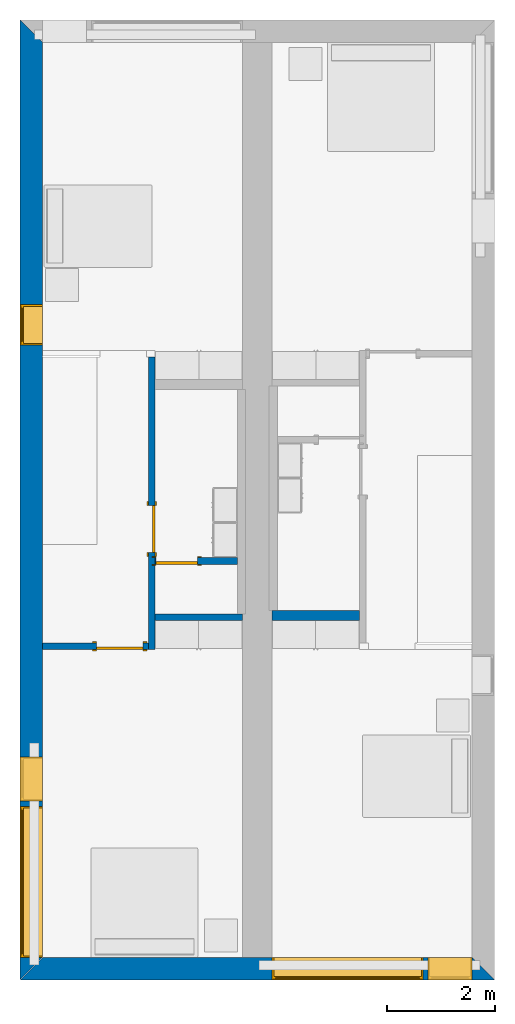
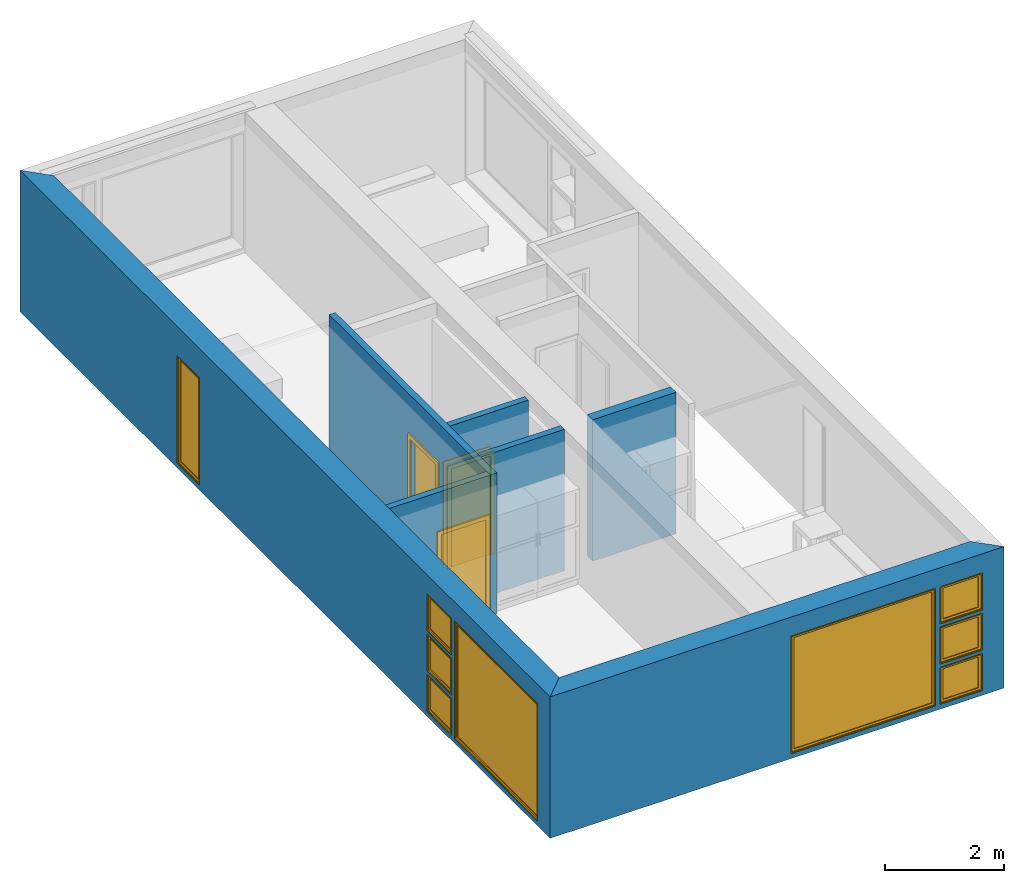
# One storey, part 2 of 16: 9 windows, 7 walls, 3 doors, 12 openings.
"""IFC2X3 building model written with IfcOpenShell, lengths in metres."""

import ifcopenshell
import ifcopenshell.guid

model = None  # the IFC model being written
_history = None  # IfcOwnerHistory: only IFC2X3 demands one
_inside = {}  # id of a spatial element -> (the spatial element, [elements in it])
_under = {}  # id of a project, library or spatial element -> (it, [spatial elements below it])
_declared = {}  # id of a project -> (the project, [libraries it declares])
_typed = {}  # id of a type object -> (the type object, [elements of that type])
_made_of = {}  # id of a material, layer set ... -> (it, [elements and type objects made of it])


def new_model(schema):
    """Start an empty IFC model of exactly this schema.

    Asked for "IFC4X3", IfcOpenShell would pick the latest addendum, in which some entities
    have other attributes; the version numbers below select the first issue.
    IFC2X3 requires an IfcOwnerHistory on every rooted entity: one is made here for all.
    """
    global model, _history
    if schema == "IFC4X3":
        model = ifcopenshell.file(schema_version=(4, 3, 0, 0))
    else:
        model = ifcopenshell.file(schema=schema)
    _inside.clear()
    _under.clear()
    _declared.clear()
    _typed.clear()
    _made_of.clear()
    _history = None
    if model.schema == "IFC2X3":
        org = make("IfcOrganization", Name="unknown")
        user = make(
            "IfcPersonAndOrganization",
            ThePerson=make("IfcPerson", FamilyName="unknown"),
            TheOrganization=org,
        )
        app = make(
            "IfcApplication",
            ApplicationDeveloper=org,
            Version="unknown",
            ApplicationFullName="unknown",
            ApplicationIdentifier="unknown",
        )
        _history = make(
            "IfcOwnerHistory",
            OwningUser=user,
            OwningApplication=app,
            ChangeAction="ADDED",
            CreationDate=0,
        )
    return model


def make(cls, **values):
    """One entity of the class cls with the attributes given. An attribute that is None is left unset."""
    return model.create_entity(
        cls, **{name: value for name, value in values.items() if value is not None}
    )


def entity(cls, *values):
    """Any entity or typed value of the class cls, its attributes in the order of the schema. None: left unset."""
    e = model.create_entity(cls)
    for i, value in enumerate(values):
        if value is not None:
            e[i] = value
    return e


def rooted(cls, **values):
    """An entity with a GlobalId (a new one), such as an element, a storey or a relation."""
    return make(cls, GlobalId=ifcopenshell.guid.new(), OwnerHistory=_history, **values)


def si_unit(unit_type, name, prefix=None):
    """IfcSIUnit, for example si_unit("LENGTHUNIT", "METRE", prefix="MILLI")."""
    return make("IfcSIUnit", UnitType=unit_type, Prefix=prefix, Name=name)


def converted_unit(unit_type, name, factor, base, dimensions=None, offset=None):
    """IfcConversionBasedUnit, such as the inch: factor (a typed value) times the base unit."""
    return make(
        "IfcConversionBasedUnit"
        if offset is None
        else "IfcConversionBasedUnitWithOffset",
        ConversionOffset=offset,
        Dimensions=None
        if dimensions is None
        else entity("IfcDimensionalExponents", *dimensions),
        UnitType=unit_type,
        Name=name,
        ConversionFactor=make(
            "IfcMeasureWithUnit", ValueComponent=factor, UnitComponent=base
        ),
    )


def assignment(units):
    """IfcUnitAssignment: the units of a project."""
    return None if units is None else make("IfcUnitAssignment", Units=units)


def point(xyz):
    """IfcCartesianPoint."""
    return None if xyz is None else make("IfcCartesianPoint", Coordinates=xyz)


def direction(xyz):
    """IfcDirection."""
    return None if xyz is None else make("IfcDirection", DirectionRatios=xyz)


def frame(location, z_axis=None, x_axis=None):
    """IfcAxis2Placement3D, a coordinate frame: its origin and axes. An axis left out is left unset."""
    return make(
        "IfcAxis2Placement3D",
        Location=point(location),
        Axis=direction(z_axis),
        RefDirection=direction(x_axis),
    )


def frame_2d(location, x_axis=None):
    """IfcAxis2Placement2D, a coordinate frame in the plane: its origin and x axis."""
    return make(
        "IfcAxis2Placement2D", Location=point(location), RefDirection=direction(x_axis)
    )


def origin():
    """The frame at (0, 0, 0) with its axes left unset."""
    return frame((0.0, 0.0, 0.0))


def origin_2d_with_axis():
    """The frame at (0, 0) in the plane with the x axis (1, 0) written out."""
    return frame_2d((0.0, 0.0), x_axis=(1.0, 0.0))


def place(relative_to, where):
    """IfcLocalPlacement: puts the frame where relative to a parent placement (None: the world)."""
    return make(
        "IfcLocalPlacement", PlacementRelTo=relative_to, RelativePlacement=where
    )


def context(
    kind, dimensions, precision=None, world=None, true_north=None, identifier=None
):
    """IfcGeometricRepresentationContext, for example the 3D "Model" context."""
    return make(
        "IfcGeometricRepresentationContext",
        ContextIdentifier=identifier,
        ContextType=kind,
        CoordinateSpaceDimension=dimensions,
        Precision=precision,
        WorldCoordinateSystem=world,
        TrueNorth=true_north,
    )


def project(units=None, contexts=None):
    """IfcProject with its units and contexts."""
    return rooted(
        "IfcProject",
        Name="project",
        RepresentationContexts=contexts,
        UnitsInContext=assignment(units),
    )


def spatial(cls, under=None, at=None, **own):
    """A site, building, storey or space (cls), placed at a placement, below another one or the project."""
    s = rooted(cls, ObjectPlacement=at, **own)
    if under is not None:
        _under.setdefault(under.id(), (under, []))[1].append(s)
    return s


def polyline(points):
    """IfcPolyline through the points."""
    return make("IfcPolyline", Points=[point(p) for p in points])


def profile(cls, at=None, kind="AREA", **sizes):
    """A parametric profile (cls). Its sizes go by their IFC names, for example OverallWidth=200.0."""
    return make(cls, ProfileType=kind, Position=at, **sizes)


def rectangle(**sizes):
    """IfcRectangleProfileDef."""
    return profile("IfcRectangleProfileDef", **sizes)


def outline(outer, holes=None, kind="AREA"):
    """IfcArbitraryClosedProfileDef: a profile drawn as a closed curve; with holes, ...WithVoids."""
    if holes is None:
        return make("IfcArbitraryClosedProfileDef", ProfileType=kind, OuterCurve=outer)
    return make(
        "IfcArbitraryProfileDefWithVoids",
        ProfileType=kind,
        OuterCurve=outer,
        InnerCurves=holes,
    )


def extrude(swept, where, along, depth):
    """IfcExtrudedAreaSolid: the profile swept, set in the frame where, extruded along a direction by depth."""
    return make(
        "IfcExtrudedAreaSolid",
        SweptArea=swept,
        Position=where,
        ExtrudedDirection=direction(along),
        Depth=depth,
    )


def shape(context_of_items, identifier, shape_type, items):
    """IfcShapeRepresentation: the items that make up one representation, for example the "Body"."""
    return make(
        "IfcShapeRepresentation",
        ContextOfItems=context_of_items,
        RepresentationIdentifier=identifier,
        RepresentationType=shape_type,
        Items=items,
    )


def source(mapping_origin, context_of_items, identifier, shape_type, items):
    """IfcRepresentationMap: a shape defined once, which mapped items show again and again."""
    return make(
        "IfcRepresentationMap",
        MappingOrigin=mapping_origin,
        MappedRepresentation=shape(context_of_items, identifier, shape_type, items),
    )


def transform(
    local_origin,
    x_axis=None,
    y_axis=None,
    z_axis=None,
    scale=None,
    scale2=None,
    scale3=None,
    uniform=True,
):
    """IfcCartesianTransformationOperator3D, or its non-uniform kind. x_axis, y_axis, z_axis: its Axis1, 2, 3."""
    if uniform:
        return make(
            "IfcCartesianTransformationOperator3D",
            Axis1=direction(x_axis),
            Axis2=direction(y_axis),
            LocalOrigin=point(local_origin),
            Scale=scale,
            Axis3=direction(z_axis),
        )
    return make(
        "IfcCartesianTransformationOperator3DnonUniform",
        Axis1=direction(x_axis),
        Axis2=direction(y_axis),
        LocalOrigin=point(local_origin),
        Scale=scale,
        Axis3=direction(z_axis),
        Scale2=scale2,
        Scale3=scale3,
    )


def mapped(mapping_source, mapping_target):
    """IfcMappedItem: shows the shape of a source again, moved by a transform."""
    return make(
        "IfcMappedItem", MappingSource=mapping_source, MappingTarget=mapping_target
    )


def material(Name=None, Category=None):
    """IfcMaterial."""
    return make("IfcMaterial", Name=Name, Category=Category)


def layer(
    of_material, thickness, ventilated=None, Name=None, Category=None, Priority=None
):
    """IfcMaterialLayer: one layer of a wall or slab, of a material (None: an air gap)."""
    return make(
        "IfcMaterialLayer",
        Material=of_material,
        LayerThickness=thickness,
        IsVentilated=ventilated,
        Name=Name,
        Category=Category,
        Priority=Priority,
    )


def layer_set(layers, Name=None):
    """IfcMaterialLayerSet."""
    return make("IfcMaterialLayerSet", MaterialLayers=layers, LayerSetName=Name)


def layer_usage(for_layer_set, set_direction, sense, offset, extent=None):
    """IfcMaterialLayerSetUsage: how a layer set lies in its element."""
    return make(
        "IfcMaterialLayerSetUsage",
        ForLayerSet=for_layer_set,
        LayerSetDirection=set_direction,
        DirectionSense=sense,
        OffsetFromReferenceLine=offset,
        ReferenceExtent=extent,
    )


def made_of(thing, what):
    """Note that an element or type object is made of a material, layer set ...; save() writes the relation."""
    if what is not None:
        _made_of.setdefault(what.id(), (what, []))[1].append(thing)
    return thing


def type_object(cls, material=None, **own):
    """A type object (cls), such as IfcWallType, which elements share."""
    return made_of(rooted(cls, **own), material)


def type_shapes(of_type, sources):
    """Give a type object the sources (RepresentationMaps) that its elements show as mapped items."""
    of_type.RepresentationMaps = sources


def element(
    cls,
    number,
    at=None,
    inside=None,
    cuts=None,
    type_object=None,
    material=None,
    context=None,
    identifier="Body",
    shape_type=None,
    held_by="IfcProductDefinitionShape",
    body=None,
    shapes=None,
    **own,
):
    """One element of the class cls, such as IfcWall. Its Tag is "e" and its number.

    at: its placement. inside: the storey or other place that contains it. cuts: it is an
    opening in that element (IfcRelVoidsElement). A single representation is given by context,
    identifier, shape_type and body (its items); several are given by shapes. held_by: the class
    of the entity that holds the representations. save() writes the other relations.
    """
    e = rooted(cls, Tag="e%d" % number, ObjectPlacement=at, **own)
    if body is not None:
        shapes = [shape(context, identifier, shape_type, body)]
    if shapes is not None:
        e.Representation = make(held_by, Representations=shapes)
    if inside is not None:
        _inside.setdefault(inside.id(), (inside, []))[1].append(e)
    if cuts is not None:
        rooted(
            "IfcRelVoidsElement", RelatingBuildingElement=cuts, RelatedOpeningElement=e
        )
    if type_object is not None:
        _typed.setdefault(type_object.id(), (type_object, []))[1].append(e)
    return made_of(e, material)


def fill(opening, filler):
    """IfcRelFillsElement: the door or window that sits in an opening."""
    return rooted(
        "IfcRelFillsElement",
        RelatingOpeningElement=opening,
        RelatedBuildingElement=filler,
    )


def aggregate(whole, parts):
    """IfcRelAggregates: a whole, such as a stair, and the parts it consists of."""
    return rooted("IfcRelAggregates", RelatingObject=whole, RelatedObjects=parts)


def save(model, path):
    """Write the relations noted so far, then the file.

    IfcRelAggregates (storeys below a building ...), IfcRelContainedInSpatialStructure (elements
    in a storey), IfcRelDefinesByType, IfcRelAssociatesMaterial and IfcRelDeclares: one each for
    every whole, place, type object, material and project.
    """
    for whole, parts in _under.values():
        aggregate(whole, parts)
    for where, things in _inside.values():
        rooted(
            "IfcRelContainedInSpatialStructure",
            RelatedElements=things,
            RelatingStructure=where,
        )
    for kind, things in _typed.values():
        rooted("IfcRelDefinesByType", RelatedObjects=things, RelatingType=kind)
    for what, things in _made_of.values():
        rooted("IfcRelAssociatesMaterial", RelatedObjects=things, RelatingMaterial=what)
    for by, libraries in _declared.values():
        rooted("IfcRelDeclares", RelatingContext=by, RelatedDefinitions=libraries)
    model.write(path)


model = new_model("IFC2X3")

# Units and contexts
model_context = context("Model", 3, precision=1e-09, world=origin())
plan_context = context("Plan", 3, precision=1e-09, world=origin())
ifc_project = project(units=[si_unit("LENGTHUNIT", "METRE"), si_unit("AREAUNIT", "SQUARE_METRE"), si_unit("VOLUMEUNIT", "CUBIC_METRE"), converted_unit("PLANEANGLEUNIT", "DEGREE", entity("IfcRatioMeasure", 0.01745329251994328), si_unit("PLANEANGLEUNIT", "RADIAN"), dimensions=[0, 0, 0, 0, 0, 0, 0]), si_unit("TIMEUNIT", "SECOND")], contexts=[model_context, plan_context])

# Site, building, storey
site_placement = place(None, origin())
site = spatial("IfcSite", under=ifc_project, at=site_placement, CompositionType="ELEMENT")
building_placement = place(site_placement, origin())
building = spatial("IfcBuilding", under=site, at=building_placement, CompositionType="ELEMENT")
storey_placement = place(building_placement, frame((0.0, 0.0, 3.100000000000196)))
storey = spatial("IfcBuildingStorey", under=building, at=storey_placement, Name="Level 2", CompositionType="ELEMENT", Elevation=3.100000000000196)

# Wall, openings, windows
ifc_material_1 = material(Name="Masonry - Brick")
ifc_layer_1 = layer(ifc_material_1, 0.092)
ifc_material_2 = material(Name="Misc. Air Layers - Air Space")
ifc_layer_2 = layer(ifc_material_2, 0.025)
ifc_material_3 = material(Name="Insulation / Thermal Barriers - Rigid insulation")
ifc_layer_3 = layer(ifc_material_3, 0.05)
ifc_material_4 = material(Name="Masonry - Concrete Block")
ifc_layer_4 = layer(ifc_material_4, 0.193)
ifc_material_5 = material(Name="Metal - Stud Layer")
ifc_layer_5 = layer(ifc_material_5, 0.041)
ifc_material_6 = material(Name="Plasterboard")
ifc_layer_6 = layer(ifc_material_6, 0.016)
ifc_layer_set_1 = layer_set([ifc_layer_1, ifc_layer_2, ifc_layer_3, ifc_layer_4, ifc_layer_5, ifc_layer_6], Name="Basic Wall:Exterior - Brick on Block")
ifc_layer_usage_1 = layer_usage(ifc_layer_set_1, "AXIS2", "NEGATIVE", 0.2085000000000001)
wall_1_placement = place(storey_placement, frame((8.799999999999974, -17.5915, 0.0), z_axis=(0.0, 0.0, 1.0), x_axis=(-1.0, 0.0, 0.0)))
wall_1 = element("IfcWallStandardCase", 1, at=wall_1_placement, inside=storey, material=ifc_layer_usage_1, Name="Basic Wall:Exterior - Brick on Block", ObjectType="Basic Wall:Exterior - Brick on Block", context=model_context, shape_type="SweptSolid", body=[
    extrude(outline(polyline([(8.382999999999974, -0.2084999999999994), (8.799999999999974, 0.2085000000000002), (0.0, 0.2085000000000002), (0.4170000000000034, -0.2085000000000011), (4.125000000000003, -0.2085000000000001), (4.675000000000003, -0.2085000000000005), (8.382999999999974, -0.2084999999999994)])), origin(), (0.0, 0.0, 1.0), 2.900000000000012),
])
opening_1_placement = place(wall_1_placement, frame((1.325000000000001, -0.2084999999999981, 0.1000000000000054)))
opening_1 = element("IfcOpeningElement", 2, at=opening_1_placement, cuts=wall_1, ObjectType="Opening", context=model_context, shape_type="SweptSolid", body=[
    extrude(rectangle(XDim=2.409999999999996, YDim=2.8, at=frame_2d((1.204999999999998, 1.4), x_axis=(1.0, 0.0))), frame((0.0, 0.0, 0.0), z_axis=(0.0, 1.0, 0.0), x_axis=(0.0, 0.0, 1.0)), (0.0, 0.0, 1.0), 0.4170000000000001),
])
opening_2_placement = place(wall_1_placement, frame((0.4170000000000005, -0.2084999999999993, 0.100000000000006)))
opening_2 = element("IfcOpeningElement", 3, at=opening_2_placement, cuts=wall_1, ObjectType="Opening", context=model_context, shape_type="SweptSolid", body=[
    extrude(rectangle(XDim=0.7589999999999981, YDim=0.8189999999999995, at=frame_2d((0.379499999999999, 0.4095000000000003), x_axis=(1.0, 0.0))), frame((0.0, 0.0, 0.0), z_axis=(0.0, 1.0, 0.0), x_axis=(0.0, 0.0, 1.0)), (0.0, 0.0, 1.0), 0.4170000000000001),
])
opening_3_placement = place(wall_1_placement, frame((0.4170000000000168, -0.2084999999999998, 0.9255000000000008)))
opening_3 = element("IfcOpeningElement", 4, at=opening_3_placement, cuts=wall_1, ObjectType="Opening", context=model_context, shape_type="SweptSolid", body=[
    extrude(rectangle(XDim=0.7590000000000007, YDim=0.8189999999999998, at=frame_2d((0.3795000000000003, 0.4094999999999999), x_axis=(-1.0, 0.0))), frame((0.0, 0.0, 0.0), z_axis=(0.0, 1.0, 0.0), x_axis=(0.0, 0.0, 1.0)), (0.0, 0.0, 1.0), 0.4170000000000001),
])
opening_4_placement = place(wall_1_placement, frame((0.4170000000000005, -0.2084999999999993, 1.751000000000001)))
opening_4 = element("IfcOpeningElement", 5, at=opening_4_placement, cuts=wall_1, ObjectType="Opening", context=model_context, shape_type="SweptSolid", body=[
    extrude(rectangle(XDim=0.7589999999999981, YDim=0.8189999999999995, at=frame_2d((0.379499999999999, 0.4095000000000003), x_axis=(1.0, 0.0))), frame((0.0, 0.0, 0.0), z_axis=(0.0, 1.0, 0.0), x_axis=(0.0, 0.0, 1.0)), (0.0, 0.0, 1.0), 0.4170000000000001),
])
window_style_1 = type_object("IfcWindowStyle", Name="2800mm x 2410mm", ConstructionType="NOTDEFINED", OperationType="NOTDEFINED", ParameterTakesPrecedence=False, Sizeable=False)
shared_shape_1 = source(origin(), model_context, "Body", "SweptSolid", [
    extrude(rectangle(XDim=0.01199999999999998, YDim=2.673999999999997, at=origin_2d_with_axis()), frame((1.400000000000007, 0.3759999999999956, 0.06299999999998514), z_axis=(0.0, 0.0, 1.0), x_axis=(0.0, -1.0, 0.0)), (0.0, 0.0, 1.0), 2.284000000000005),
    extrude(outline(polyline([(-1.381, -1.186000000000001), (1.381, -1.186000000000001), (1.381, 1.186000000000001), (-1.381, 1.186000000000001), (-1.381, -1.186000000000001)]), holes=[polyline([(-1.336999999999999, -1.142000000000002), (-1.336999999999999, 1.142000000000003), (1.336999999999997, 1.142000000000003), (1.336999999999997, -1.142000000000002), (-1.336999999999999, -1.142000000000002)])]), frame((1.400000000000008, 0.3539999999999681, 1.204999999999988), z_axis=(0.0, 1.0, 0.0), x_axis=(1.0, 0.0, 0.0)), (0.0, 0.0, 1.0), 0.04400000000002743),
    extrude(outline(polyline([(-1.4, -1.204999999999996), (1.4, -1.204999999999996), (1.4, 1.204999999999996), (-1.4, 1.204999999999996), (-1.4, -1.204999999999996)]), holes=[polyline([(-1.381000000000001, -1.185999999999981), (-1.381000000000001, 1.186000000000022), (1.380999999999999, 1.186000000000022), (1.380999999999999, -1.185999999999981), (-1.381000000000001, -1.185999999999981)])]), frame((1.400000000000009, 0.3539999999999681, 1.205000000000009), z_axis=(0.0, 1.0, 0.0), x_axis=(1.0, 0.0, 0.0)), (0.0, 0.0, 1.0), 0.06300000000002744),
    extrude(outline(polyline([(-1.4, -1.204999999999995), (1.4, -1.204999999999995), (1.4, 1.204999999999995), (-1.4, 1.204999999999995), (-1.4, -1.204999999999995)]), holes=[polyline([(-1.368, -1.172999999999982), (-1.368, 1.17300000000002), (1.368, 1.17300000000002), (1.367999999999999, -1.172999999999982), (-1.368, -1.172999999999982)])]), frame((1.40000000000001, 0.0, 1.205000000000008), z_axis=(0.0, 1.0, 0.0), x_axis=(1.0, 0.0, 0.0)), (0.0, 0.0, 1.0), 0.3539999999999727),
])
type_shapes(window_style_1, [shared_shape_1])
window_1_placement = place(opening_1_placement, origin())
window_1 = element("IfcWindow", 6, at=window_1_placement, inside=storey, type_object=window_style_1, ObjectType="2800mm x 2410mm", OverallHeight=2.409999999999996, OverallWidth=2.8, context=model_context, shape_type="MappedRepresentation", body=[
    mapped(shared_shape_1, transform((0.0, 0.0, 0.0), scale=1.0)),
])
fill(opening_1, window_1)
window_style_2 = type_object("IfcWindowStyle", Name="819mm x 759mm", ConstructionType="NOTDEFINED", OperationType="NOTDEFINED", ParameterTakesPrecedence=False, Sizeable=False)
shared_shape_2 = source(origin(), model_context, "Body", "SweptSolid", [
    extrude(rectangle(XDim=0.01199999999999998, YDim=0.6929999999999971, at=origin_2d_with_axis()), frame((0.4095000000000068, 0.3759999999999988, 0.06299999999998514), z_axis=(0.0, 0.0, 1.0), x_axis=(0.0, -1.0, 0.0)), (0.0, 0.0, 1.0), 0.6330000000000073),
    extrude(outline(polyline([(-0.3904999999999999, -0.3605000000000028), (0.3904999999999999, -0.3605000000000028), (0.3904999999999999, 0.3605000000000027), (-0.3904999999999999, 0.3605000000000027), (-0.3904999999999999, -0.3605000000000028)]), holes=[polyline([(-0.3464999999999996, -0.3165000000000033), (-0.3464999999999996, 0.316500000000004), (0.3464999999999974, 0.316500000000004), (0.3464999999999974, -0.3165000000000033), (-0.3464999999999996, -0.3165000000000033)])]), frame((0.4095000000000078, 0.3539999999999714, 0.3794999999999891), z_axis=(0.0, 1.0, 0.0), x_axis=(1.0, 0.0, 0.0)), (0.0, 0.0, 1.0), 0.04400000000002743),
    extrude(outline(polyline([(-0.4094999999999998, -0.3794999999999972), (0.4094999999999998, -0.3794999999999972), (0.4094999999999998, 0.3794999999999971), (-0.4094999999999998, 0.3794999999999971), (-0.4094999999999998, -0.3794999999999972)]), holes=[polyline([(-0.3905000000000011, -0.3604999999999823), (-0.3905000000000012, 0.3605000000000231), (0.3904999999999986, 0.3605000000000231), (0.3904999999999987, -0.3604999999999823), (-0.3905000000000011, -0.3604999999999823)])]), frame((0.4095000000000091, 0.3539999999999714, 0.3795000000000096), z_axis=(0.0, 1.0, 0.0), x_axis=(1.0, 0.0, 0.0)), (0.0, 0.0, 1.0), 0.06300000000002744),
    extrude(outline(polyline([(-0.4095000000000002, -0.3794999999999967), (0.4095000000000002, -0.3794999999999967), (0.4095000000000002, 0.3794999999999966), (-0.4095000000000002, 0.3794999999999966), (-0.4095000000000002, -0.3794999999999967)]), holes=[polyline([(-0.3774999999999999, -0.3474999999999832), (-0.3774999999999999, 0.3475000000000212), (0.3775000000000001, 0.3475000000000212), (0.3775000000000001, -0.3474999999999832), (-0.3774999999999999, -0.3474999999999832)])]), frame((0.4095000000000096, 0.0, 0.379500000000009), z_axis=(0.0, 1.0, 0.0), x_axis=(1.0, 0.0, 0.0)), (0.0, 0.0, 1.0), 0.3539999999999727),
])
type_shapes(window_style_2, [shared_shape_2])
window_2_placement = place(opening_2_placement, origin())
window_2 = element("IfcWindow", 7, at=window_2_placement, inside=storey, type_object=window_style_2, ObjectType="819mm x 759mm", OverallHeight=0.758999999999998, OverallWidth=0.8190000000000001, context=model_context, shape_type="MappedRepresentation", body=[
    mapped(shared_shape_2, transform((0.0, 0.0, 0.0), scale=1.0)),
])
fill(opening_2, window_2)
window_3_placement = place(opening_4_placement, origin())
window_3 = element("IfcWindow", 8, at=window_3_placement, inside=storey, type_object=window_style_2, ObjectType="819mm x 759mm", OverallHeight=0.758999999999998, OverallWidth=0.8190000000000001, context=model_context, shape_type="MappedRepresentation", body=[
    mapped(shared_shape_2, transform((0.0, 0.0, 0.0), scale=1.0)),
])
fill(opening_4, window_3)
window_style_3 = type_object("IfcWindowStyle", Name="819mm x 759mm", ConstructionType="NOTDEFINED", OperationType="NOTDEFINED", ParameterTakesPrecedence=False, Sizeable=False)
shared_shape_3 = source(origin(), model_context, "Body", "SweptSolid", [
    extrude(rectangle(XDim=0.01269999999999999, YDim=0.6919999999999978, at=origin_2d_with_axis()), frame((0.4095000000000003, 0.3757750000000001, 0.06350000000000397), z_axis=(0.0, 0.0, 1.0), x_axis=(0.0, 1.0, 0.0)), (0.0, 0.0, 1.0), 0.6320000000000041),
    extrude(outline(polyline([(-0.3904499999999989, -0.3604500000000012), (0.3904499999999989, -0.3604500000000012), (0.3904499999999989, 0.3604500000000012), (-0.3904499999999989, 0.3604500000000012), (-0.3904499999999989, -0.3604500000000012)]), holes=[polyline([(-0.3459999999999978, -0.3160000000000016), (-0.3459999999999978, 0.3160000000000026), (0.346, 0.3160000000000026), (0.346, -0.3160000000000016), (-0.3459999999999978, -0.3160000000000016)])]), frame((0.4094999999999992, 0.3535500000000001, 0.3795000000000066), z_axis=(0.0, 1.0, 0.0), x_axis=(1.0, 0.0, 0.0)), (0.0, 0.0, 1.0), 0.04445),
    extrude(outline(polyline([(-0.4094999999999992, -0.3795000000000012), (0.4094999999999992, -0.3795000000000012), (0.4094999999999992, 0.3795000000000012), (-0.4094999999999992, 0.3795000000000012), (-0.4094999999999992, -0.3795000000000012)]), holes=[polyline([(-0.3777500000000001, -0.3477499999999997), (-0.3777500000000001, 0.3477500000000008), (0.3777499999999982, 0.3477500000000008), (0.3777499999999982, -0.3477499999999997), (-0.3777500000000001, -0.3477499999999997)])]), frame((0.4095000000000007, 0.0, 0.3795000000000077), z_axis=(0.0, 1.0, 0.0), x_axis=(1.0, 0.0, 0.0)), (0.0, 0.0, 1.0), 0.3535500000000001),
    extrude(outline(polyline([(-0.3795000000000017, -0.4094999999999995), (0.3795000000000017, -0.4094999999999995), (0.3795000000000017, 0.4094999999999995), (-0.3795000000000017, 0.4094999999999995), (-0.3795000000000017, -0.4094999999999995)]), holes=[polyline([(-0.3604500000000023, -0.3904499999999987), (-0.3604500000000023, 0.3904499999999997), (0.3604500000000017, 0.3904499999999997), (0.3604500000000017, -0.3904499999999988), (-0.3604500000000023, -0.3904499999999987)])]), frame((0.4095000000000004, 0.3535500000000001, 0.3795000000000071), z_axis=(0.0, 1.0, 0.0), x_axis=(0.0, 0.0, -1.0)), (0.0, 0.0, 1.0), 0.06345),
])
type_shapes(window_style_3, [shared_shape_3])
window_4_placement = place(opening_3_placement, origin())
window_4 = element("IfcWindow", 9, at=window_4_placement, inside=storey, type_object=window_style_3, ObjectType="819mm x 759mm", OverallHeight=0.7590000000000007, OverallWidth=0.8190000000000001, context=model_context, shape_type="MappedRepresentation", body=[
    mapped(shared_shape_3, transform((0.0, 0.0, 0.0), scale=1.0)),
])
fill(opening_3, window_4)

ifc_layer_usage_2 = layer_usage(ifc_layer_set_1, "AXIS2", "NEGATIVE", 0.2085000000000001)
wall_2_placement = place(storey_placement, frame((0.208499999999999, -17.79999999999997, 0.0), z_axis=(0.0, 0.0, 1.0), x_axis=(0.0, 1.0, 0.0)))
wall_2 = element("IfcWallStandardCase", 10, at=wall_2_placement, inside=storey, material=ifc_layer_usage_2, Name="Basic Wall:Exterior - Brick on Block", ObjectType="Basic Wall:Exterior - Brick on Block", context=model_context, shape_type="SweptSolid", body=[
    extrude(outline(polyline([(17.38299999999997, -0.2085000000000001), (17.79999999999997, 0.2085000000000001), (0.0, 0.2085000000000001), (0.4170000000000005, -0.2085), (6.125999999999976, -0.2085), (6.249999999999976, -0.2085000000000001), (17.38299999999997, -0.2085000000000001)])), origin(), (0.0, 0.0, 1.0), 2.900000000000013),
])
opening_5_placement = place(wall_2_placement, frame((0.4169999999999983, -0.2084999999999956, 0.1000000000000011)))
opening_5 = element("IfcOpeningElement", 11, at=opening_5_placement, cuts=wall_2, ObjectType="Opening", context=model_context, shape_type="SweptSolid", body=[
    extrude(rectangle(XDim=2.409999999999996, YDim=2.8, at=frame_2d((1.204999999999998, 1.4), x_axis=(1.0, 0.0))), frame((0.0, 0.0, 0.0), z_axis=(0.0, 1.0, 0.0), x_axis=(0.0, 0.0, 1.0)), (0.0, 0.0, 1.0), 0.4170000000000001),
])
opening_6_placement = place(wall_2_placement, frame((3.317, -0.208499999999999, 1.751000000000001)))
opening_6 = element("IfcOpeningElement", 12, at=opening_6_placement, cuts=wall_2, ObjectType="Opening", context=model_context, shape_type="SweptSolid", body=[
    extrude(rectangle(XDim=0.7589999999999981, YDim=0.8189999999999995, at=frame_2d((0.379499999999999, 0.4095000000000003), x_axis=(1.0, 0.0))), frame((0.0, 0.0, 0.0), z_axis=(0.0, 1.0, 0.0), x_axis=(0.0, 0.0, 1.0)), (0.0, 0.0, 1.0), 0.4170000000000001),
])
opening_7_placement = place(wall_2_placement, frame((3.317, -0.208499999999999, 0.1000000000000011)))
opening_7 = element("IfcOpeningElement", 13, at=opening_7_placement, cuts=wall_2, ObjectType="Opening", context=model_context, shape_type="SweptSolid", body=[
    extrude(rectangle(XDim=0.7589999999999981, YDim=0.8189999999999995, at=frame_2d((0.3794999999999993, 0.4095000000000003), x_axis=(1.0, 0.0))), frame((0.0, 0.0, 0.0), z_axis=(0.0, 1.0, 0.0), x_axis=(0.0, 0.0, 1.0)), (0.0, 0.0, 1.0), 0.4170000000000001),
])
opening_8_placement = place(wall_2_placement, frame((3.317000000000015, -0.2085000000000003, 0.9255000000000008)))
opening_8 = element("IfcOpeningElement", 14, at=opening_8_placement, cuts=wall_2, ObjectType="Opening", context=model_context, shape_type="SweptSolid", body=[
    extrude(rectangle(XDim=0.7590000000000007, YDim=0.8189999999999998, at=frame_2d((0.3795000000000003, 0.4094999999999999), x_axis=(-1.0, 0.0))), frame((0.0, 0.0, 0.0), z_axis=(0.0, 1.0, 0.0), x_axis=(0.0, 0.0, 1.0)), (0.0, 0.0, 1.0), 0.4170000000000001),
])
opening_9_placement = place(wall_2_placement, frame((11.77399999999997, -0.2084999999999996, 0.1000000000000011)))
opening_9 = element("IfcOpeningElement", 15, at=opening_9_placement, cuts=wall_2, ObjectType="Opening", context=model_context, shape_type="SweptSolid", body=[
    extrude(rectangle(XDim=2.199999999999996, YDim=0.7499999999999996, at=frame_2d((1.099999999999999, 0.3749999999999987), x_axis=(1.0, 0.0))), frame((0.0, 0.0, 0.0), z_axis=(0.0, 1.0, 0.0), x_axis=(0.0, 0.0, 1.0)), (0.0, 0.0, 1.0), 0.4170000000000001),
])
window_style_4 = type_object("IfcWindowStyle", Name="750mm x 2200mm", ConstructionType="NOTDEFINED", OperationType="NOTDEFINED", ParameterTakesPrecedence=False, Sizeable=False)
shared_shape_4 = source(origin(), model_context, "Body", "SweptSolid", [
    extrude(rectangle(XDim=0.01199999999999998, YDim=0.623999999999997, at=origin_2d_with_axis()), frame((0.375000000000007, 0.3759999999999988, 0.06299999999998514), z_axis=(0.0, 0.0, 1.0), x_axis=(0.0, -1.0, 0.0)), (0.0, 0.0, 1.0), 2.074000000000006),
    extrude(outline(polyline([(-0.3559999999999999, -1.081000000000002), (0.3559999999999999, -1.081000000000002), (0.3559999999999999, 1.081000000000002), (-0.3559999999999999, 1.081000000000002), (-0.3559999999999999, -1.081000000000002)]), holes=[polyline([(-0.3119999999999996, -1.037000000000002), (-0.3119999999999996, 1.037000000000003), (0.3119999999999975, 1.037000000000003), (0.3119999999999975, -1.037000000000002), (-0.3119999999999996, -1.037000000000002)])]), frame((0.3750000000000081, 0.3539999999999715, 1.099999999999989), z_axis=(0.0, 1.0, 0.0), x_axis=(1.0, 0.0, 0.0)), (0.0, 0.0, 1.0), 0.04400000000002743),
    extrude(outline(polyline([(-0.3749999999999997, -1.099999999999996), (0.3749999999999997, -1.099999999999996), (0.3749999999999997, 1.099999999999996), (-0.3749999999999997, 1.099999999999996), (-0.3749999999999997, -1.099999999999996)]), holes=[polyline([(-0.3560000000000012, -1.080999999999981), (-0.3560000000000013, 1.081000000000022), (0.3559999999999985, 1.081000000000022), (0.3559999999999986, -1.080999999999981), (-0.3560000000000012, -1.080999999999981)])]), frame((0.3750000000000094, 0.3539999999999715, 1.100000000000009), z_axis=(0.0, 1.0, 0.0), x_axis=(1.0, 0.0, 0.0)), (0.0, 0.0, 1.0), 0.06300000000002744),
    extrude(outline(polyline([(-0.3750000000000001, -1.099999999999996), (0.3750000000000001, -1.099999999999996), (0.3750000000000001, 1.099999999999996), (-0.3750000000000001, 1.099999999999996), (-0.3750000000000001, -1.099999999999996)]), holes=[polyline([(-0.3429999999999999, -1.067999999999982), (-0.3429999999999999, 1.06800000000002), (0.3430000000000001, 1.06800000000002), (0.3430000000000001, -1.067999999999982), (-0.3429999999999999, -1.067999999999982)])]), frame((0.3750000000000099, 0.0, 1.100000000000008), z_axis=(0.0, 1.0, 0.0), x_axis=(1.0, 0.0, 0.0)), (0.0, 0.0, 1.0), 0.3539999999999727),
])
type_shapes(window_style_4, [shared_shape_4])
window_5_placement = place(opening_9_placement, origin())
window_5 = element("IfcWindow", 16, at=window_5_placement, inside=storey, type_object=window_style_4, ObjectType="750mm x 2200mm", OverallHeight=2.199999999999997, OverallWidth=0.7499999999999996, context=model_context, shape_type="MappedRepresentation", body=[
    mapped(shared_shape_4, transform((0.0, 0.0, 0.0), scale=1.0)),
])
fill(opening_9, window_5)
window_6_placement = place(opening_5_placement, origin())
window_6 = element("IfcWindow", 17, at=window_6_placement, inside=storey, type_object=window_style_1, ObjectType="2800mm x 2410mm", OverallHeight=2.409999999999996, OverallWidth=2.8, context=model_context, shape_type="MappedRepresentation", body=[
    mapped(shared_shape_1, transform((0.0, 0.0, 0.0), scale=1.0)),
])
fill(opening_5, window_6)
window_7_placement = place(opening_6_placement, origin())
window_7 = element("IfcWindow", 18, at=window_7_placement, inside=storey, type_object=window_style_2, ObjectType="819mm x 759mm", OverallHeight=0.758999999999998, OverallWidth=0.8190000000000001, context=model_context, shape_type="MappedRepresentation", body=[
    mapped(shared_shape_2, transform((0.0, 0.0, 0.0), scale=1.0)),
])
fill(opening_6, window_7)
window_8_placement = place(opening_7_placement, origin())
window_8 = element("IfcWindow", 19, at=window_8_placement, inside=storey, type_object=window_style_2, ObjectType="819mm x 759mm", OverallHeight=0.7589999999999986, OverallWidth=0.8190000000000001, context=model_context, shape_type="MappedRepresentation", body=[
    mapped(shared_shape_2, transform((0.0, 0.0, 0.0), scale=1.0)),
])
fill(opening_7, window_8)
window_9_placement = place(opening_8_placement, origin())
window_9 = element("IfcWindow", 20, at=window_9_placement, inside=storey, type_object=window_style_3, ObjectType="819mm x 759mm", OverallHeight=0.7590000000000007, OverallWidth=0.8190000000000001, context=model_context, shape_type="MappedRepresentation", body=[
    mapped(shared_shape_3, transform((0.0, 0.0, 0.0), scale=1.0)),
])
fill(opening_8, window_9)

# Wall, opening, door
ifc_layer_7 = layer(ifc_material_6, 0.016)
ifc_layer_8 = layer(ifc_material_5, 0.092)
ifc_layer_9 = layer(ifc_material_6, 0.016)
ifc_layer_set_2 = layer_set([ifc_layer_7, ifc_layer_8, ifc_layer_9], Name="Basic Wall:Interior - Partition (92mm Stud)")
ifc_layer_usage_3 = layer_usage(ifc_layer_set_2, "AXIS2", "NEGATIVE", 0.062)
wall_3_placement = place(storey_placement, frame((2.444, -6.250000000000009, 0.0), z_axis=(0.0, 0.0, 1.0), x_axis=(0.0, -1.0, 0.0)))
wall_3 = element("IfcWallStandardCase", 21, at=wall_3_placement, inside=storey, material=ifc_layer_usage_3, Name="Basic Wall:Interior - Partition (92mm Stud)", ObjectType="Basic Wall:Interior - Partition (92mm Stud)", context=model_context, shape_type="SweptSolid", body=[
    extrude(rectangle(XDim=5.423999999999995, YDim=0.1240000000000002, at=frame_2d((2.711999999999998, 0.0), x_axis=(-1.0, 0.0))), origin(), (0.0, 0.0, 1.0), 2.900000000000012),
])
opening_10_placement = place(wall_3_placement, frame((2.75605117851058, -0.06200000000000567, 0.0)))
opening_10 = element("IfcOpeningElement", 22, at=opening_10_placement, cuts=wall_3, Name="M_Single-Flush:0864 x 2032mm:0864 x 2032mm:1", ObjectType="Opening", context=model_context, shape_type="SweptSolid", body=[
    extrude(rectangle(XDim=0.8639999999999994, YDim=2.032, at=frame_2d((1.016, 0.4319999999999993), x_axis=(0.0, 1.0))), frame((0.0, 0.0, 0.0), z_axis=(0.0, 1.0, 0.0), x_axis=(0.0, 0.0, 1.0)), (0.0, 0.0, 1.0), 0.124),
])
door_style_1 = type_object("IfcDoorStyle", Name="0864 x 2032mm", ConstructionType="NOTDEFINED", OperationType="SINGLE_SWING_RIGHT", ParameterTakesPrecedence=False, Sizeable=False)
shared_shape_5 = source(origin(), model_context, "Body", "SweptSolid", [
    extrude(outline(polyline([(-0.5079999999999999, -1.072999999999999), (0.5079999999999998, -1.072999999999999), (0.5079999999999998, 1.035000000000001), (0.4319999999999997, 1.035000000000001), (0.4319999999999997, -0.9970000000000019), (-0.4319999999999996, -0.9970000000000019), (-0.4319999999999996, 1.035000000000001), (-0.5079999999999999, 1.035000000000001), (-0.5079999999999999, -1.072999999999999)])), frame((0.4320000000000008, 0.1239999999999992, 1.035000000000001), z_axis=(0.0, 1.0, 0.0), x_axis=(1.0, 0.0, 0.0)), (0.0, 0.0, 1.0), 0.02499999999999444),
    extrude(outline(polyline([(-1.073, -0.5079999999999971), (1.035, -0.5079999999999971), (1.035, -0.4320000000000073), (-0.9969999999999997, -0.4320000000000073), (-0.9969999999999997, 0.4320000000000018), (1.035, 0.4320000000000018), (1.035, 0.5080000000000027), (-1.073, 0.5080000000000027), (-1.073, -0.5079999999999971)])), frame((0.4320000000000031, -0.02500000000000638, 1.035), z_axis=(0.0, 1.0, 0.0), x_axis=(0.0, 0.0, -1.0)), (0.0, 0.0, 1.0), 0.02500000000000558),
    extrude(rectangle(XDim=0.051, YDim=0.8639999999999998, at=origin_2d_with_axis()), frame((0.4320000000000005, 0.0984999999999992, 0.0), z_axis=(0.0, 0.0, 1.0), x_axis=(0.0, 1.0, 0.0)), (0.0, 0.0, 1.0), 2.032),
])
type_shapes(door_style_1, [shared_shape_5])
door_1_placement = place(opening_10_placement, origin())
door_1 = element("IfcDoor", 23, at=door_1_placement, inside=storey, type_object=door_style_1, Name="M_Single-Flush:0864 x 2032mm:0864 x 2032mm", ObjectType="0864 x 2032mm", OverallHeight=2.032, OverallWidth=0.8639999999999985, context=model_context, shape_type="MappedRepresentation", body=[
    mapped(shared_shape_5, transform((0.0, 0.0, 0.0), scale=1.0)),
])
fill(opening_10, door_1)

ifc_layer_usage_4 = layer_usage(ifc_layer_set_2, "AXIS2", "NEGATIVE", 0.062)
wall_4_placement = place(storey_placement, frame((2.381999999999991, -11.612, 0.0), z_axis=(0.0, 0.0, 1.0), x_axis=(-1.0, 0.0, 0.0)))
wall_4 = element("IfcWallStandardCase", 24, at=wall_4_placement, inside=storey, material=ifc_layer_usage_4, Name="Basic Wall:Interior - Partition (92mm Stud)", ObjectType="Basic Wall:Interior - Partition (92mm Stud)", context=model_context, shape_type="SweptSolid", body=[
    extrude(rectangle(XDim=1.964999999999992, YDim=0.1240000000000021, at=frame_2d((0.9824999999999962, 0.0), x_axis=(-1.0, 0.0))), origin(), (0.0, 0.0, 1.0), 2.900000000000012),
])
opening_11_placement = place(wall_4_placement, frame((0.09999999999999892, -0.0620000000000021, 0.0)))
opening_11 = element("IfcOpeningElement", 25, at=opening_11_placement, cuts=wall_4, Name="M_Single-Flush:0864 x 2032mm:0864 x 2032mm:1", ObjectType="Opening", context=model_context, shape_type="SweptSolid", body=[
    extrude(rectangle(XDim=0.8639999999999994, YDim=2.032, at=frame_2d((1.016, 0.4319999999999998), x_axis=(0.0, -1.0))), frame((0.0, 0.0, 0.0), z_axis=(0.0, 1.0, 0.0), x_axis=(0.0, 0.0, 1.0)), (0.0, 0.0, 1.0), 0.124),
])
door_style_2 = type_object("IfcDoorStyle", Name="0864 x 2032mm", ConstructionType="NOTDEFINED", OperationType="SINGLE_SWING_LEFT", ParameterTakesPrecedence=False, Sizeable=False)
shared_shape_6 = source(origin(), model_context, "Body", "SweptSolid", [
    extrude(outline(polyline([(-0.5079999999999999, -1.072999999999999), (0.5079999999999998, -1.072999999999999), (0.5079999999999998, 1.035000000000001), (0.4319999999999997, 1.035000000000001), (0.4319999999999997, -0.9970000000000019), (-0.4319999999999996, -0.9970000000000019), (-0.4319999999999996, 1.035000000000001), (-0.5079999999999999, 1.035000000000001), (-0.5079999999999999, -1.072999999999999)])), frame((0.4320000000000002, 0.1489999999999882, 1.035000000000001), z_axis=(0.0, -1.0, 0.0), x_axis=(-1.0, 0.0, 0.0)), (0.0, 0.0, 1.0), 0.02499999999999444),
    extrude(outline(polyline([(-1.073, -0.5079999999999971), (1.035, -0.5079999999999971), (1.035, -0.4320000000000073), (-0.9969999999999997, -0.4320000000000073), (-0.9969999999999997, 0.4320000000000018), (1.035, 0.4320000000000018), (1.035, 0.5080000000000027), (-1.073, 0.5080000000000027), (-1.073, -0.5079999999999971)])), frame((0.4319999999999979, 0.0, 1.035), z_axis=(0.0, -1.0, 0.0), x_axis=(0.0, 0.0, -1.0)), (0.0, 0.0, 1.0), 0.02500000000000558),
    extrude(rectangle(XDim=0.8639999999999998, YDim=0.051, at=origin_2d_with_axis()), frame((0.4320000000000005, 0.09849999999999375, 0.0)), (0.0, 0.0, 1.0), 2.032),
])
type_shapes(door_style_2, [shared_shape_6])
door_2_placement = place(opening_11_placement, origin())
door_2 = element("IfcDoor", 26, at=door_2_placement, inside=storey, type_object=door_style_2, Name="M_Single-Flush:0864 x 2032mm:0864 x 2032mm", ObjectType="0864 x 2032mm", OverallHeight=2.032, OverallWidth=0.8639999999999995, context=model_context, shape_type="MappedRepresentation", body=[
    mapped(shared_shape_6, transform((0.0, 0.0, 0.0), scale=1.0)),
])
fill(opening_11, door_2)

# Walls
ifc_layer_usage_5 = layer_usage(ifc_layer_set_2, "AXIS2", "NEGATIVE", 0.062)
wall_5_placement = place(storey_placement, frame((4.124999999999983, -11.072, 0.0), z_axis=(0.0, 0.0, 1.0), x_axis=(-1.0, 0.0, 0.0)))
element("IfcWallStandardCase", 27, at=wall_5_placement, inside=storey, material=ifc_layer_usage_5, Name="Basic Wall:Interior - Partition (92mm Stud)", ObjectType="Basic Wall:Interior - Partition (92mm Stud)", context=model_context, shape_type="SweptSolid", body=[
    extrude(rectangle(XDim=1.61899999999999, YDim=0.1240000000000021, at=frame_2d((0.8094999999999952, 0.0), x_axis=(-1.0, 0.0))), origin(), (0.0, 0.0, 1.0), 2.900000000000012),
])
ifc_layer_10 = layer(ifc_material_6, 0.016)
ifc_layer_11 = layer(ifc_material_5, 0.152)
ifc_layer_12 = layer(ifc_material_6, 0.016)
ifc_layer_set_3 = layer_set([ifc_layer_10, ifc_layer_11, ifc_layer_12], Name="Basic Wall:Interior - Plumbing (152mm Stud)")
ifc_layer_usage_6 = layer_usage(ifc_layer_set_3, "AXIS2", "NEGATIVE", 0.092)
wall_6_placement = place(storey_placement, frame((6.294000000000001, -11.04200000000001, 0.0), z_axis=(0.0, 0.0, 1.0), x_axis=(-1.0, 0.0, 0.0)))
element("IfcWallStandardCase", 28, at=wall_6_placement, inside=storey, material=ifc_layer_usage_6, Name="Basic Wall:Interior - Plumbing (152mm Stud)", ObjectType="Basic Wall:Interior - Plumbing (152mm Stud)", context=model_context, shape_type="SweptSolid", body=[
    extrude(rectangle(XDim=1.619000000000018, YDim=0.1840000000000015, at=frame_2d((0.8095000000000092, 0.0), x_axis=(-1.0, 0.0))), origin(), (0.0, 0.0, 1.0), 2.900000000000012),
])

# Wall, opening, door
ifc_layer_usage_7 = layer_usage(ifc_layer_set_2, "AXIS2", "NEGATIVE", 0.062)
wall_7_placement = place(storey_placement, frame((4.029999999999983, -10.03205117851059, 0.0), z_axis=(0.0, 0.0, 1.0), x_axis=(-1.0, 0.0, 0.0)))
wall_7 = element("IfcWallStandardCase", 29, at=wall_7_placement, inside=storey, material=ifc_layer_usage_7, Name="Basic Wall:Interior - Partition (92mm Stud)", ObjectType="Basic Wall:Interior - Partition (92mm Stud)", context=model_context, shape_type="SweptSolid", body=[
    extrude(rectangle(XDim=1.52399999999999, YDim=0.1240000000000021, at=frame_2d((0.7619999999999951, 0.0), x_axis=(-1.0, 0.0))), origin(), (0.0, 0.0, 1.0), 2.900000000000012),
])
opening_12_placement = place(wall_7_placement, frame((0.7419999999999857, -0.0619999999999989, 0.0)))
opening_12 = element("IfcOpeningElement", 30, at=opening_12_placement, cuts=wall_7, Name="M_Single-Flush:0762 x 2032mm:0762 x 2032mm:1", ObjectType="Opening", context=model_context, shape_type="SweptSolid", body=[
    extrude(rectangle(XDim=0.7619999999999997, YDim=2.032, at=frame_2d((1.016, 0.3810000000000001), x_axis=(0.0, 1.0))), frame((0.0, 0.0, 0.0), z_axis=(0.0, 1.0, 0.0), x_axis=(0.0, 0.0, 1.0)), (0.0, 0.0, 1.0), 0.124),
])
door_style_3 = type_object("IfcDoorStyle", Name="0762 x 2032mm", ConstructionType="NOTDEFINED", OperationType="SINGLE_SWING_RIGHT", ParameterTakesPrecedence=False, Sizeable=False)
shared_shape_7 = source(origin(), model_context, "Body", "SweptSolid", [
    extrude(outline(polyline([(-0.457, -1.072999999999999), (0.4569999999999999, -1.072999999999999), (0.4569999999999999, 1.035000000000001), (0.3809999999999998, 1.035000000000001), (0.3809999999999998, -0.9970000000000019), (-0.3809999999999997, -0.9970000000000019), (-0.3809999999999997, 1.035000000000001), (-0.457, 1.035000000000001), (-0.457, -1.072999999999999)])), frame((0.3810000000000009, 0.1239999999999993, 1.035000000000001), z_axis=(0.0, 1.0, 0.0), x_axis=(1.0, 0.0, 0.0)), (0.0, 0.0, 1.0), 0.02499999999999445),
    extrude(outline(polyline([(-1.073, -0.4569999999999971), (1.035, -0.4569999999999971), (1.035, -0.3810000000000074), (-0.9969999999999997, -0.3810000000000074), (-0.9969999999999997, 0.3810000000000018), (1.035, 0.3810000000000018), (1.035, 0.4570000000000027), (-1.073, 0.4570000000000027), (-1.073, -0.4569999999999971)])), frame((0.3810000000000031, -0.02500000000000627, 1.035), z_axis=(0.0, 1.0, 0.0), x_axis=(0.0, 0.0, -1.0)), (0.0, 0.0, 1.0), 0.02500000000000558),
    extrude(rectangle(XDim=0.051, YDim=0.7619999999999998, at=origin_2d_with_axis()), frame((0.3810000000000005, 0.09849999999999928, 0.0), z_axis=(0.0, 0.0, 1.0), x_axis=(0.0, 1.0, 0.0)), (0.0, 0.0, 1.0), 2.032),
])
type_shapes(door_style_3, [shared_shape_7])
door_3_placement = place(opening_12_placement, origin())
door_3 = element("IfcDoor", 31, at=door_3_placement, inside=storey, type_object=door_style_3, Name="M_Single-Flush:0762 x 2032mm:0762 x 2032mm", ObjectType="0762 x 2032mm", OverallHeight=2.032, OverallWidth=0.762, context=model_context, shape_type="MappedRepresentation", body=[
    mapped(shared_shape_7, transform((0.0, 0.0, 0.0), scale=1.0)),
])
fill(opening_12, door_3)

save(model, "model.ifc")
